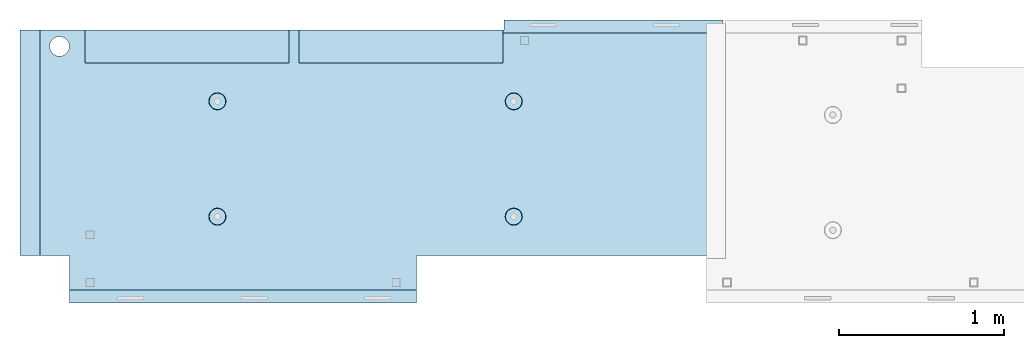
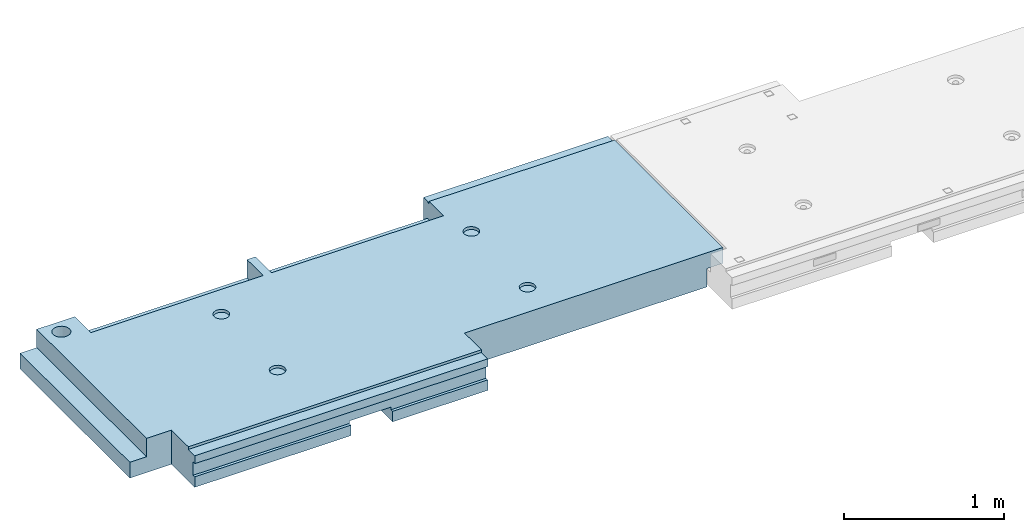
# One storey, part 2 of 3: 1 slab, 1 element without a shape of its own.
"""IFC2X3 building model written with IfcOpenShell, lengths in millimetres."""

from ifc_helpers import new_model, si_unit, frame, origin_with_axes, place, context, subcontext, project, spatial, faceted_brep, material, type_object, element, aggregate, save


model = new_model("IFC2X3")

# Units and contexts
model_context = context("Model", 3, precision=1e-05, world=origin_with_axes())
body_context = subcontext(model_context, "Body", "Model", "MODEL_VIEW")
ifc_project = project(units=[si_unit("LENGTHUNIT", "METRE", prefix="MILLI"), si_unit("AREAUNIT", "SQUARE_METRE"), si_unit("VOLUMEUNIT", "CUBIC_METRE"), si_unit("MASSUNIT", "GRAM", prefix="KILO"), si_unit("TIMEUNIT", "SECOND"), si_unit("PLANEANGLEUNIT", "RADIAN"), si_unit("SOLIDANGLEUNIT", "STERADIAN"), si_unit("THERMODYNAMICTEMPERATUREUNIT", "DEGREE_CELSIUS"), si_unit("LUMINOUSINTENSITYUNIT", "LUMEN")], contexts=[model_context])

# Site, building, storey
site_placement = place(None, origin_with_axes())
site = spatial("IfcSite", under=ifc_project, at=site_placement, CompositionType="ELEMENT")
building_placement = place(site_placement, origin_with_axes())
building = spatial("IfcBuilding", under=site, at=building_placement, Name="Undefined", CompositionType="ELEMENT")
storey_placement = place(building_placement, origin_with_axes())
storey = spatial("IfcBuildingStorey", under=building, at=storey_placement, Name="3", CompositionType="ELEMENT", Elevation=0.0)

# Assembly, slab
assembly_placement = place(storey_placement, origin_with_axes())
assembly = element("IfcElementAssembly", 1, at=assembly_placement, inside=storey, AssemblyPlace="NOTDEFINED", PredefinedType="REINFORCEMENT_UNIT")
ifc_material = material(Name="CONCRETE/C25/30")
slab_type = type_object("IfcSlabType", PredefinedType="NOTDEFINED")
slab_placement = place(assembly_placement, frame((23540.0159390845, 15510.0026483125, 90620.0), z_axis=(-0.999999999997437, -2.26400000064461e-06, 0.0), x_axis=(-2.2639999995273e-06, 0.999999999997437, 0.0)))
slab = element("IfcSlab", 2, at=slab_placement, type_object=slab_type, material=ifc_material, PredefinedType="FLOOR", context=body_context, shape_type="Brep", body=[
    faceted_brep([(-269.991394356101, 30.0, 2845.00213671412), (-79.9935682977648, 30.0, 2845.00213671301), (-79.9942474988402, 30.0, 2545.001661275), (-269.991475956112, 30.0, 2545.00209142873), (-79.9935682977648, 130.0, 2845.00213671301), (-269.991394356102, 50.0011356208415, 2845.00213671412), (-289.993566176285, 50.0011356208415, 2845.00213671423), (-289.993566176285, 130.0, 2845.00213671423), (-79.9942474988402, 130.0, 2545.001661275), (-289.994243058944, 130.0, 2545.00213671499), (-289.994243058944, 50.0011356208415, 2545.00213671499), (-269.991475956114, 50.0011356208415, 2545.00209142873), (250.667816023648, -110.0, 1223.00869116667), (264.606228919523, -110.0, 1230.11066726268), (275.667816023648, -110.0, 1241.1722543668), (282.76979211966, -110.0, 1255.11066726268), (285.216966304903, -110.0, 1270.56151698143), (282.769792119658, -110.0, 1286.01236670018), (275.667816023648, -110.0, 1299.95077959605), (264.606228919525, -110.0, 1311.01236670018), (250.667816023648, -110.0, 1318.11434279619), (235.216966304901, -110.0, 1320.56151698143), (219.766116586154, -110.0, 1318.11434279619), (205.827703690276, -110.0, 1311.01236670018), (194.766116586154, -110.0, 1299.95077959605), (187.664140490142, -110.0, 1286.01236670018), (185.216966304899, -110.0, 1270.56151698143), (187.664140490144, -110.0, 1255.11066726268), (194.766116586154, -110.0, 1241.1722543668), (205.827703690276, -110.0, 1230.11066726268), (219.766116586154, -110.0, 1223.00869116667), (235.216966304901, -110.0, 1220.56151698143), (251.370127374501, -130.0, 1220.84719908418), (235.216966304901, -130.0, 1218.2887897087), (265.942104492917, -130.0, 1228.27199227546), (277.506491010863, -130.0, 1239.83637879341), (284.931284202146, -130.0, 1254.40835591183), (287.489693577627, -130.0, 1270.56151698143), (284.931284202146, -130.0, 1286.71467805103), (277.506491010861, -130.0, 1301.28665516945), (265.942104492917, -130.0, 1312.85104168739), (251.370127374501, -130.0, 1320.27583487867), (235.216966304901, -130.0, 1322.83424425416), (219.063805235301, -130.0, 1320.27583487867), (204.491828116883, -130.0, 1312.85104168739), (192.927441598938, -130.0, 1301.28665516945), (185.502648407655, -130.0, 1286.71467805103), (182.944239032175, -130.0, 1270.56151698143), (185.502648407655, -130.0, 1254.40835591183), (192.92744159894, -130.0, 1239.83637879341), (204.491828116883, -130.0, 1228.27199227546), (219.063805235301, -130.0, 1220.84719908418), (1370.00988769532, 9.99999999994179, 4270.0029296875), (0.00703133410206647, 9.99999999994179, 4270.00341796875), (0.00594789032584231, 9.99999999994179, 4150.00335886026), (1370.00950450419, 9.99999999994179, 4150.0022190173), (1370.00988769532, 130.0, 4270.0029296875), (0.00703133410206647, 130.0, 4270.00341796875), (-289.995788574217, 50.0011356208415, 1860.01696777343), (-269.99166227209, 50.0011356208415, 1860.01689198933), (-289.995788574217, 130.0, 1860.01696777343), (1410.00403637765, -10.0000000000582, 115.00218916441), (-0.000334584017764428, -10.0000000000582, 115.003668258996), (-0.000334584015945438, 130.0, 115.003668258996), (1430.00436377147, 130.0, 115.002168181909), (1430.00283514406, 50.0011356437899, 115.002168184747), (1410.00403637764, 50.0011356208415, 115.002189163421), (1430.00659179688, 130.0, 1330.01220703125), (1370.00036621094, 130.0, 1330.01281738281), (1370.00036621094, -110.000000000073, 1330.01281738281), (1430.00659179688, -110.000000000073, 1330.01220703125), (1430.00656714066, -110.000000000073, 1.33804860524833e-08), (1350.00656713971, -110.000000000073, -1.09139364212751e-10), (1350.00656713971, -130.0, -9.31322574615479e-10), (0.0, -130.0, -3.63797880709171e-12), (0.0, -10.0, 0.0), (1410.00416932017, -10.0000000000582, 1.69893610291183e-09), (1410.00416932017, -49.9988643791585, 5.89352566748858e-10), (1430.00416932019, -49.9988643791585, 2.83398549072444e-09), (1430.00277003324, 50.0011356208415, 1270.01537795496), (1430.00277003324, -49.9988643791585, 1270.01537795496), (1410.00277003325, 50.0011356208415, 1270.01535591496), (1410.00277003325, -49.9988643791585, 1270.01535591496), (-0.00148380931932479, -130.0, 510.016937255856), (-0.00148380931932479, 130.0, 510.016937255856), (0.00156440050341189, -130.0, 1860.01586914062), (0.00156440050341189, 130.0, 1860.01586914062), (-209.991713751984, -130.000000000058, 1860.01666468411), (-209.996345203012, -130.0, 3970.01713194715), (-209.996345203012, -110.000000000058, 3970.01713194715), (-209.991713751984, -110.000000000058, 1860.01666468411), (-289.991027832028, -110.000000000058, 3970.01733398437), (-289.995788574217, -110.000000000058, 1860.01696777343), (-289.991027832028, -49.9988643791585, 3970.01733398437), (-289.995788574217, -49.9988643791585, 1860.01696777343), (-269.99166227209, -49.9988643791585, 1860.01689198933), (-289.991027832028, 50.0011356208415, 3970.01733398437), (-289.991027832028, 130.0, 3970.01733398437), (-269.991088351981, 50.0011356208415, 3970.01728347186), (-269.991088351981, -49.9988643791585, 3970.01728347186), (0.00432284502676339, -130.0, 3970.0166015625), (0.00432284502676339, 130.0, 3970.0166015625), (0.00594789032584231, -130.0, 4150.00335886026), (1370.00950450419, -130.000000000058, 4150.0022190173), (1370.00860847198, 9.99639270307671, 3875.01157736929), (1170.00318277859, 9.99639270307671, 3875.01203018158), (1170.00037541444, 9.99639270307671, 2635.01019913007), (1370.00459258838, 9.99639270307671, 2635.00974632052), (1370.00860847197, -130.000000000058, 3875.01157736929), (1170.00318277859, -130.000000000029, 3875.01203018158), (1170.00037541444, -130.000000000029, 2635.01019913007), (1370.00459258838, -130.000000000029, 2635.00974632052), (1370.00439827764, -130.000000000029, 2575.01157737549), (1170.00023957859, -130.000000000029, 2575.01203018491), (1170.00023957859, 9.99639270307671, 2575.01203018491), (1370.00439827764, 9.99639270307671, 2575.01157737549), (1169.99743221444, -130.000000000029, 1335.0101991334), (1169.99743221444, 9.99639270307671, 1335.0101991334), (1370.00038239405, 9.99639270307671, 1335.00974632672), (1370.00038239405, -110.000000000073, 1335.00974632672), (1350.00004294686, -110.000000000073, 1335.00979160748), (1350.00004294686, -130.000000000073, 1335.00979160748), (920.332855772751, -110.0, 1318.11282667454), (906.394410719273, -110.0, 1311.01091369173), (895.332773528397, -110.0, 1299.94937667459), (888.230734319324, -110.0, 1286.01099593661), (885.78349017266, -110.0, 1270.56015729882), (888.230594396427, -110.0, 1255.10929649942), (895.332507379233, -110.0, 1241.17085144594), (906.394044396377, -110.0, 1230.10921425507), (920.332425134358, -110.0, 1223.00717504599), (935.783263772144, -110.0, 1220.55993089933), (951.234124571543, -110.0, 1223.0070351231), (965.172569625021, -110.0, 1230.10894810591), (976.234206815898, -110.0, 1241.17048512305), (983.33624602497, -110.0, 1255.10886586103), (985.783490171634, -110.0, 1270.55970449882), (983.336385947867, -110.0, 1286.01056529821), (976.234472965061, -110.0, 1299.94901035169), (965.172935947918, -110.0, 1311.01064754257), (951.234555209936, -110.0, 1318.11268675164), (935.783716572147, -110.0, 1320.5599308983), (951.936426135147, -130.0, 1220.84553986057), (935.783253481237, -130.0, 1218.28720362663), (966.508436872882, -130.0, 1228.27026706986), (978.072875754253, -130.0, 1239.83460122415), (985.497734927369, -130.0, 1254.40654472295), (988.05621744434, -130.0, 1270.55969420791), (985.497881210395, -130.0, 1286.71286686182), (978.073154001104, -130.0, 1301.28487759955), (966.508819846818, -130.0, 1312.84931648092), (951.936876348012, -130.0, 1320.27417565404), (935.783726863054, -130.0, 1322.83265817101), (919.630554209147, -130.0, 1320.27432193707), (905.058543471412, -130.0, 1312.84959472777), (893.494104590041, -130.0, 1301.28526057349), (886.069245416922, -130.0, 1286.71331707469), (883.510762899954, -130.0, 1270.56016758973), (886.069099133892, -130.0, 1254.40699493582), (893.49382634319, -130.0, 1239.83498419809), (905.058160497476, -130.0, 1228.27054531671), (919.630103996282, -130.0, 1220.84568614359), (920.336931380272, -110.0, 3118.29282666992), (906.398486326791, -110.0, 3111.19091368712), (895.336849135918, -110.0, 3100.12937666997), (888.234809926846, -110.0, 3086.19099593199), (885.787565780181, -110.0, 3070.7401572942), (888.234670003949, -110.0, 3055.28929649481), (895.336582986754, -110.0, 3041.35085144133), (906.398120003898, -110.0, 3030.28921425045), (920.33650074188, -110.0, 3023.18717504138), (935.787339379665, -110.0, 3020.73993089472), (951.238200179065, -110.0, 3023.18703511849), (965.176645232543, -110.0, 3030.28894810129), (976.238282423419, -110.0, 3041.35048511844), (983.340321632491, -110.0, 3055.28886585642), (985.787565779156, -110.0, 3070.7397044942), (983.340461555388, -110.0, 3086.1905652936), (976.238548572583, -110.0, 3100.12901034708), (965.177011555439, -110.0, 3111.19064753796), (951.238630817454, -110.0, 3118.29268674703), (935.787792179664, -110.0, 3120.73993089369), (951.940501742669, -130.000000000015, 3021.02553985595), (935.787329088758, -130.000000000015, 3018.46720362201), (966.512512480404, -130.000000000015, 3028.45026706525), (978.076951361778, -130.000000000015, 3040.01460121954), (985.50181053489, -130.000000000015, 3054.58654471834), (988.060293051862, -130.000000000015, 3070.73969420329), (985.501956817916, -130.000000000015, 3086.89286685721), (978.077229608625, -130.000000000015, 3101.46487759494), (966.51289545434, -130.000000000015, 3113.02931647631), (951.940951955534, -130.000000000015, 3120.45417564943), (935.787802470575, -130.000000000015, 3123.01265816639), (919.634629816665, -130.000000000015, 3120.45432193246), (905.062619078933, -130.000000000015, 3113.02959472316), (893.498180197559, -130.000000000015, 3101.46526056888), (886.07332102444, -130.000000000015, 3086.89331707007), (883.514838507475, -130.000000000015, 3070.74016758511), (886.073174741414, -130.000000000015, 3054.5869949312), (893.497901950712, -130.000000000015, 3040.01498419347), (905.062236104997, -130.000000000015, 3028.4505453121), (919.634179603803, -130.000000000015, 3021.02568613898), (250.671891631169, -110.0, 3023.18869116206), (264.610304527045, -110.0, 3030.29066725807), (275.671891631167, -110.0, 3041.35225436219), (282.773867727179, -110.0, 3055.29066725806), (285.221041912424, -110.0, 3070.74151697681), (282.773867727179, -110.0, 3086.19236669556), (275.671891631169, -110.0, 3100.13077959144), (264.610304527047, -110.0, 3111.19236669556), (250.671891631169, -110.0, 3118.29434279157), (235.221041912422, -110.0, 3120.74151697681), (219.770192193675, -110.0, 3118.29434279157), (205.831779297798, -110.0, 3111.19236669556), (194.770192193675, -110.0, 3100.13077959144), (187.668216097663, -110.0, 3086.19236669556), (185.22104191242, -110.0, 3070.74151697681), (187.668216097663, -110.0, 3055.29066725806), (194.770192193673, -110.0, 3041.35225436219), (205.831779297798, -110.0, 3030.29066725807), (219.770192193673, -110.0, 3023.18869116206), (235.221041912422, -110.0, 3020.74151697681), (251.374202982022, -130.0, 3021.02719907957), (235.221041912422, -130.0, 3018.46878970409), (265.946180100438, -130.0, 3028.45199227085), (277.510566618384, -130.0, 3040.0163787888), (284.935359809668, -130.0, 3054.58835590722), (287.493769185148, -130.0, 3070.74151697681), (284.935359809668, -130.0, 3086.89467804641), (277.510566618383, -130.0, 3101.46665516483), (265.946180100438, -130.0, 3113.03104168278), (251.374202982022, -130.0, 3120.45583487406), (235.22104191242, -130.0, 3123.01424424954), (219.067880842822, -130.0, 3120.45583487406), (204.495903724404, -130.0, 3113.03104168278), (192.93151720646, -130.0, 3101.46665516483), (185.506724015177, -130.0, 3086.89467804641), (182.948314639694, -130.0, 3070.74151697681), (185.506724015177, -130.0, 3054.58835590722), (192.93151720646, -130.0, 3040.0163787888), (204.495903724404, -130.0, 3028.45199227085), (219.06788084282, -130.0, 3021.02719907957), (1234.74413944682, -130.000000000029, 3981.4733287671), (1221.47026497402, -130.000000000029, 3994.74726334413), (1212.94793152671, -130.000000000029, 4011.47337811379), (1210.0113644813, -130.000000000029, 4030.01440442472), (1212.94801548044, -130.000000000029, 4048.55541743869), (1221.47042466352, -130.000000000029, 4065.28149361904), (1234.74435924055, -130.000000000029, 4078.55536809184), (1251.47047401021, -130.000000000029, 4087.07770153915), (1270.01150032114, -130.000000000029, 4090.01426858456), (1288.55251333511, -130.000000000029, 4087.07761758541), (1305.27858951547, -130.000000000029, 4078.55520840234), (1318.55246398826, -130.000000000029, 4065.28127382531), (1327.07479743557, -130.000000000029, 4048.55515905565), (1330.01136448099, -130.000000000029, 4030.01413274472), (1327.07471348184, -130.000000000029, 4011.47311973075), (1318.55230429877, -130.000000000029, 3994.74704355039), (1305.27836972173, -130.000000000029, 3981.4731690776), (1288.55225495208, -130.000000000029, 3972.95083563029), (1270.01122864114, -130.000000000029, 3970.01426858487), (1251.47021562717, -130.000000000029, 3972.95091958403), (1305.27836972173, 130.0, 3981.4731690776), (1288.55225495208, 130.0, 3972.95083563029), (1318.55230429877, 130.0, 3994.74704355039), (1327.07471348184, 130.0, 4011.47311973075), (1330.01136448099, 130.0, 4030.01413274472), (1327.07479743557, 130.0, 4048.55515905565), (1318.55246398826, 130.0, 4065.28127382531), (1305.27858951547, 130.0, 4078.55520840234), (1288.55251333511, 130.0, 4087.07761758541), (1270.01150032114, 130.0, 4090.01426858456), (1251.47047401021, 130.0, 4087.07770153915), (1234.74435924055, 130.0, 4078.55536809184), (1221.47042466352, 130.0, 4065.28149361904), (1212.94801548044, 130.0, 4048.55541743869), (1210.0113644813, 130.0, 4030.01440442472), (1212.94793152671, 130.0, 4011.47337811379), (1221.47026497402, 130.0, 3994.74726334413), (1234.74413944682, 130.0, 3981.4733287671), (1251.47021562717, 130.0, 3972.95091958403), (1270.01122864114, 130.0, 3970.01426858487)], [[[0, 1, 2, 3]], [[4, 1, 0, 5, 6, 7]], [[8, 2, 1, 4]], [[9, 10, 11, 3, 2, 8]], [[12, 13, 14, 15, 16, 17, 18, 19, 20, 21, 22, 23, 24, 25, 26, 27, 28, 29, 30, 31]], [[32, 12, 31, 33]], [[34, 13, 12, 32]], [[35, 14, 13, 34]], [[36, 15, 14, 35]], [[37, 16, 15, 36]], [[38, 17, 16, 37]], [[39, 18, 17, 38]], [[40, 19, 18, 39]], [[41, 20, 19, 40]], [[42, 21, 20, 41]], [[43, 22, 21, 42]], [[44, 23, 22, 43]], [[45, 24, 23, 44]], [[46, 25, 24, 45]], [[47, 26, 25, 46]], [[48, 27, 26, 47]], [[49, 28, 27, 48]], [[50, 29, 28, 49]], [[51, 30, 29, 50]], [[33, 31, 30, 51]], [[52, 53, 54, 55]], [[56, 57, 53, 52]], [[58, 59, 11, 10]], [[60, 58, 10, 9]], [[61, 62, 63, 64, 65, 66]], [[67, 68, 69, 70]], [[71, 72, 73, 74, 75, 76, 77, 78]], [[79, 65, 64, 67, 70, 71, 78, 80]], [[65, 79, 81, 66]], [[80, 82, 81, 79]], [[78, 77, 82, 80]], [[76, 61, 66, 81, 82, 77]], [[75, 62, 61, 76]], [[74, 83, 84, 63, 62, 75]], [[83, 85, 86, 84]], [[87, 88, 89, 90]], [[90, 89, 91, 92]], [[92, 91, 93, 94]], [[58, 60, 86, 85, 87, 90, 92, 94, 95, 59]], [[96, 97, 7, 6]], [[98, 96, 6, 5]], [[59, 95, 99, 98, 5, 0, 3, 11]], [[94, 93, 99, 95]], [[91, 89, 88, 100, 101, 97, 96, 98, 99, 93]], [[53, 57, 101, 100, 102, 54]], [[103, 55, 54, 102]], [[104, 105, 106, 107]], [[108, 109, 105, 104]], [[110, 106, 105, 109]], [[111, 107, 106, 110]], [[112, 113, 114, 115]], [[116, 117, 114, 113]], [[115, 114, 117, 118]], [[69, 68, 56, 52, 55, 103, 108, 104, 107, 111, 112, 115, 118, 119]], [[72, 71, 70, 69, 119, 120]], [[73, 72, 120, 121]], [[119, 118, 117, 116, 121, 120]], [[122, 123, 124, 125, 126, 127, 128, 129, 130, 131, 132, 133, 134, 135, 136, 137, 138, 139, 140, 141]], [[142, 132, 131, 143]], [[144, 133, 132, 142]], [[145, 134, 133, 144]], [[146, 135, 134, 145]], [[147, 136, 135, 146]], [[148, 137, 136, 147]], [[149, 138, 137, 148]], [[150, 139, 138, 149]], [[151, 140, 139, 150]], [[152, 141, 140, 151]], [[153, 122, 141, 152]], [[154, 123, 122, 153]], [[155, 124, 123, 154]], [[156, 125, 124, 155]], [[157, 126, 125, 156]], [[158, 127, 126, 157]], [[159, 128, 127, 158]], [[160, 129, 128, 159]], [[161, 130, 129, 160]], [[143, 131, 130, 161]], [[162, 163, 164, 165, 166, 167, 168, 169, 170, 171, 172, 173, 174, 175, 176, 177, 178, 179, 180, 181]], [[182, 172, 171, 183]], [[184, 173, 172, 182]], [[185, 174, 173, 184]], [[186, 175, 174, 185]], [[187, 176, 175, 186]], [[188, 177, 176, 187]], [[189, 178, 177, 188]], [[190, 179, 178, 189]], [[191, 180, 179, 190]], [[192, 181, 180, 191]], [[193, 162, 181, 192]], [[194, 163, 162, 193]], [[195, 164, 163, 194]], [[196, 165, 164, 195]], [[197, 166, 165, 196]], [[198, 167, 166, 197]], [[199, 168, 167, 198]], [[200, 169, 168, 199]], [[201, 170, 169, 200]], [[183, 171, 170, 201]], [[202, 203, 204, 205, 206, 207, 208, 209, 210, 211, 212, 213, 214, 215, 216, 217, 218, 219, 220, 221]], [[222, 202, 221, 223]], [[224, 203, 202, 222]], [[225, 204, 203, 224]], [[226, 205, 204, 225]], [[227, 206, 205, 226]], [[228, 207, 206, 227]], [[229, 208, 207, 228]], [[230, 209, 208, 229]], [[231, 210, 209, 230]], [[232, 211, 210, 231]], [[233, 212, 211, 232]], [[234, 213, 212, 233]], [[235, 214, 213, 234]], [[236, 215, 214, 235]], [[237, 216, 215, 236]], [[238, 217, 216, 237]], [[239, 218, 217, 238]], [[240, 219, 218, 239]], [[241, 220, 219, 240]], [[223, 221, 220, 241]], [[113, 112, 111, 110, 109, 108, 103, 102, 100, 88, 87, 85, 83, 74, 73, 121, 116], [240, 239, 238, 237, 236, 235, 234, 233, 232, 231, 230, 229, 228, 227, 226, 225, 224, 222, 223, 241], [200, 199, 198, 197, 196, 195, 194, 193, 192, 191, 190, 189, 188, 187, 186, 185, 184, 182, 183, 201], [160, 159, 158, 157, 156, 155, 154, 153, 152, 151, 150, 149, 148, 147, 146, 145, 144, 142, 143, 161], [50, 49, 48, 47, 46, 45, 44, 43, 42, 41, 40, 39, 38, 37, 36, 35, 34, 32, 33, 51], [242, 243, 244, 245, 246, 247, 248, 249, 250, 251, 252, 253, 254, 255, 256, 257, 258, 259, 260, 261]], [[258, 262, 263, 259]], [[257, 264, 262, 258]], [[256, 265, 264, 257]], [[255, 266, 265, 256]], [[254, 267, 266, 255]], [[253, 268, 267, 254]], [[252, 269, 268, 253]], [[251, 270, 269, 252]], [[250, 271, 270, 251]], [[249, 272, 271, 250]], [[248, 273, 272, 249]], [[247, 274, 273, 248]], [[246, 275, 274, 247]], [[245, 276, 275, 246]], [[244, 277, 276, 245]], [[243, 278, 277, 244]], [[242, 279, 278, 243]], [[261, 280, 279, 242]], [[260, 281, 280, 261]], [[259, 263, 281, 260]], [[7, 97, 101, 57, 56, 68, 67, 64, 63, 84, 86, 60, 9, 8, 4], [262, 264, 265, 266, 267, 268, 269, 270, 271, 272, 273, 274, 275, 276, 277, 278, 279, 280, 281, 263]]]),
])
aggregate(assembly, [slab])

save(model, "model.ifc")
